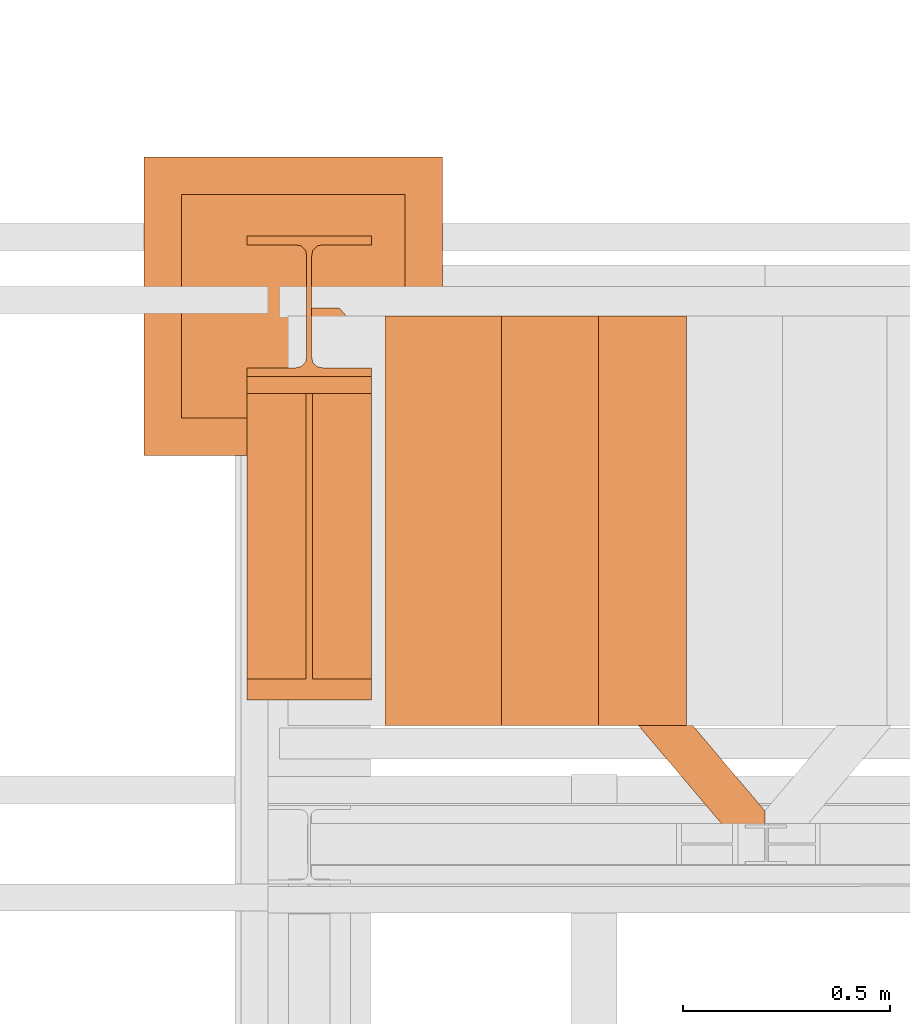
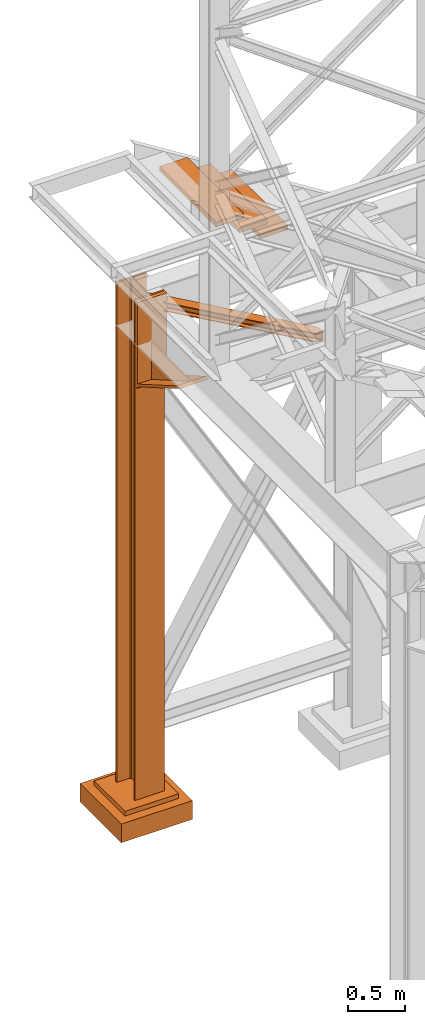
# One storey, part 132 of 208: 7 proxies.
"""IFC2X3 building model written with IfcOpenShell, lengths in millimetres."""

from ifc_helpers import new_model, entity, si_unit, converted_unit, frame, origin, origin_with_axes, place, context, subcontext, project, spatial, faceted_brep, material, element, save


model = new_model("IFC2X3")

# Units and contexts
model_context = context("Model", 3, precision=1e-05, world=origin())
plan_context = context("Plan", 3, precision=1e-05, world=origin())
body_context = subcontext(model_context, "Body", "Model", "MODEL_VIEW")
ifc_project = project(units=[si_unit("LENGTHUNIT", "METRE", prefix="MILLI"), converted_unit("PLANEANGLEUNIT", "DEGREE", entity("IfcPlaneAngleMeasure", 0.0174532925199433), si_unit("PLANEANGLEUNIT", "RADIAN"), dimensions=[0, 0, 0, 0, 0, 0, 0]), si_unit("AREAUNIT", "SQUARE_METRE"), si_unit("VOLUMEUNIT", "CUBIC_METRE")], contexts=[model_context, plan_context])

# Building, storey
building_placement = place(None, origin())
building = spatial("IfcBuilding", under=ifc_project, at=building_placement, CompositionType="COMPLEX")
storey_placement = place(building_placement, origin_with_axes())
storey = spatial("IfcBuildingStorey", under=building, at=storey_placement, Name="Geschoss", CompositionType="ELEMENT")

# Proxies
ifc_material = material(Name="35/80cm")
proxy_1_placement = place(storey_placement, frame((-3456.745037431798, -12632.57439531565, -65.01000000000022), z_axis=(0.0, 0.0, 1.0), x_axis=(1.0, 0.0, 0.0)))
element("IfcBuildingElementProxy", 1, at=proxy_1_placement, inside=storey, material=ifc_material, context=body_context, shape_type="Brep", body=[
    faceted_brep([(300.0100119209292, 0.01000000000021828, 0.01000000000027512), (300.0100119209292, 21.51000631809256, 0.01000000000027512), (183.0100057816508, 21.51000631809256, 0.01000000000027512), (169.036290997863, 24.30682016372703, 0.01000000000027512), (158.8068282401564, 34.53628850936912, 0.01000000000027512), (156.0100060126188, 48.51000143051169, 0.01000000000027512), (156.0100060126188, 291.5099946951868, 0.01000000000027512), (158.8068282401564, 305.48371506691, 0.01000000000027512), (169.036290997863, 315.7131685113909, 0.01000000000027512), (183.0100057816508, 318.5099972581866, 0.01000000000027512), (300.0100119209292, 318.5099972581866, 0.01000000000027512), (300.0100119209292, 340.0100035762789, 0.01000000000027512), (0.01000000000021828, 340.0100035762789, 0.01000000000027512), (0.01000000000021828, 318.5099972581866, 0.01000000000027512), (117.0100061392786, 318.5099972581866, 0.01000000000027512), (130.9837209230664, 315.7131685113909, 0.01000000000027512), (141.213183680773, 305.48371506691, 0.01000000000027512), (144.0100059083106, 291.5099946951868, 0.01000000000027512), (144.0100059083106, 48.51000143051169, 0.01000000000027512), (141.213183680773, 34.53628850936912, 0.01000000000027512), (130.9837209230664, 24.30682016372703, 0.01000000000027512), (117.0100061392786, 21.51000631809256, 0.01000000000027512), (0.01000000000021828, 21.51000631809256, 0.01000000000027512), (0.01000000000021828, 0.01000000000021828, 0.01000000000027512), (300.0100119209292, 21.51000631809256, 5350.010005364416), (300.0100119209292, 0.01000000000021828, 5350.010005364416), (0.01000000000021828, 0.01000000000021828, 5350.010005364416), (0.01000000000021828, 21.51000631809256, 5350.010005364416), (117.0100061392786, 21.51000631809256, 5350.010005364416), (130.9837209230664, 24.30682016372703, 5350.010005364416), (141.213183680773, 34.53628850936912, 5350.010005364416), (144.0100059083106, 48.51000143051169, 5350.010005364416), (144.0100059083106, 291.5099946951868, 5350.010005364416), (141.213183680773, 305.48371506691, 5350.010005364416), (130.9837209230664, 315.7131685113909, 5350.010005364416), (117.0100061392786, 318.5099972581866, 5350.010005364416), (0.01000000000021828, 318.5099972581866, 5350.010005364416), (0.01000000000021828, 340.0100035762789, 5350.010005364416), (300.0100119209292, 340.0100035762789, 5350.010005364416), (300.0100119209292, 318.5099972581866, 5350.010005364416), (183.0100057816508, 318.5099972581866, 5350.010005364416), (169.036290997863, 315.7131685113909, 5350.010005364416), (158.8068282401564, 305.48371506691, 5350.010005364416), (156.0100060126188, 291.5099946951868, 5350.010005364416), (156.0100060126188, 48.51000143051169, 5350.010005364416), (158.8068282401564, 34.53628850936912, 5350.010005364416), (169.036290997863, 24.30682016372703, 5350.010005364416), (183.0100057816508, 21.51000631809256, 5350.010005364416), (300.0100119209292, 21.51000631809256, 0.01000000000027512), (300.0100119209292, 0.01000000000021828, 0.01000000000027512), (300.0100119209292, 0.01000000000021828, 5350.010005364416), (300.0100119209292, 21.51000631809256, 5350.010005364416), (183.0100057816508, 21.51000631809256, 0.01000000000027512), (300.0100119209292, 21.51000631809256, 0.01000000000027512), (300.0100119209292, 21.51000631809256, 5350.010005364416), (183.0100057816508, 21.51000631809256, 5350.010005364416), (169.036290997863, 24.30682016372703, 0.01000000000027512), (183.0100057816508, 21.51000631809256, 0.01000000000027512), (183.0100057816508, 21.51000631809256, 5350.010005364416), (169.036290997863, 24.30682016372703, 5350.010005364416), (158.8068282401564, 34.53628850936912, 0.01000000000027512), (169.036290997863, 24.30682016372703, 0.01000000000027512), (169.036290997863, 24.30682016372703, 5350.010005364416), (158.8068282401564, 34.53628850936912, 5350.010005364416), (156.0100060126188, 48.51000143051169, 0.01000000000027512), (158.8068282401564, 34.53628850936912, 0.01000000000027512), (158.8068282401564, 34.53628850936912, 5350.010005364416), (156.0100060126188, 48.51000143051169, 5350.010005364416), (156.0100060126188, 291.5099946951868, 0.01000000000027512), (156.0100060126188, 48.51000143051169, 0.01000000000027512), (156.0100060126188, 48.51000143051169, 5350.010005364416), (156.0100060126188, 291.5099946951868, 5350.010005364416), (158.8068282401564, 305.48371506691, 0.01000000000027512), (156.0100060126188, 291.5099946951868, 0.01000000000027512), (156.0100060126188, 291.5099946951868, 5350.010005364416), (158.8068282401564, 305.48371506691, 5350.010005364416), (169.036290997863, 315.7131685113909, 0.01000000000027512), (158.8068282401564, 305.48371506691, 0.01000000000027512), (158.8068282401564, 305.48371506691, 5350.010005364416), (169.036290997863, 315.7131685113909, 5350.010005364416), (183.0100057816508, 318.5099972581866, 0.01000000000027512), (169.036290997863, 315.7131685113909, 0.01000000000027512), (169.036290997863, 315.7131685113909, 5350.010005364416), (183.0100057816508, 318.5099972581866, 5350.010005364416), (300.0100119209292, 318.5099972581866, 0.01000000000027512), (183.0100057816508, 318.5099972581866, 0.01000000000027512), (183.0100057816508, 318.5099972581866, 5350.010005364416), (300.0100119209292, 318.5099972581866, 5350.010005364416), (300.0100119209292, 340.0100035762789, 0.01000000000027512), (300.0100119209292, 318.5099972581866, 0.01000000000027512), (300.0100119209292, 318.5099972581866, 5350.010005364416), (300.0100119209292, 340.0100035762789, 5350.010005364416), (0.01000000000021828, 340.0100035762789, 0.01000000000027512), (300.0100119209292, 340.0100035762789, 0.01000000000027512), (300.0100119209292, 340.0100035762789, 5350.010005364416), (0.01000000000021828, 340.0100035762789, 5350.010005364416), (0.01000000000021828, 318.5099972581866, 0.01000000000027512), (0.01000000000021828, 340.0100035762789, 0.01000000000027512), (0.01000000000021828, 340.0100035762789, 5350.010005364416), (0.01000000000021828, 318.5099972581866, 5350.010005364416), (117.0100061392786, 318.5099972581866, 0.01000000000027512), (0.01000000000021828, 318.5099972581866, 0.01000000000027512), (0.01000000000021828, 318.5099972581866, 5350.010005364416), (117.0100061392786, 318.5099972581866, 5350.010005364416), (130.9837209230664, 315.7131685113909, 0.01000000000027512), (117.0100061392786, 318.5099972581866, 0.01000000000027512), (117.0100061392786, 318.5099972581866, 5350.010005364416), (130.9837209230664, 315.7131685113909, 5350.010005364416), (141.213183680773, 305.48371506691, 0.01000000000027512), (130.9837209230664, 315.7131685113909, 0.01000000000027512), (130.9837209230664, 315.7131685113909, 5350.010005364416), (141.213183680773, 305.48371506691, 5350.010005364416), (144.0100059083106, 291.5099946951868, 0.01000000000027512), (141.213183680773, 305.48371506691, 0.01000000000027512), (141.213183680773, 305.48371506691, 5350.010005364416), (144.0100059083106, 291.5099946951868, 5350.010005364416), (144.0100059083106, 48.51000143051169, 0.01000000000027512), (144.0100059083106, 291.5099946951868, 0.01000000000027512), (144.0100059083106, 291.5099946951868, 5350.010005364416), (144.0100059083106, 48.51000143051169, 5350.010005364416), (141.213183680773, 34.53628850936912, 0.01000000000027512), (144.0100059083106, 48.51000143051169, 0.01000000000027512), (144.0100059083106, 48.51000143051169, 5350.010005364416), (141.213183680773, 34.53628850936912, 5350.010005364416), (130.9837209230664, 24.30682016372703, 0.01000000000027512), (141.213183680773, 34.53628850936912, 0.01000000000027512), (141.213183680773, 34.53628850936912, 5350.010005364416), (130.9837209230664, 24.30682016372703, 5350.010005364416), (117.0100061392786, 21.51000631809256, 0.01000000000027512), (130.9837209230664, 24.30682016372703, 0.01000000000027512), (130.9837209230664, 24.30682016372703, 5350.010005364416), (117.0100061392786, 21.51000631809256, 5350.010005364416), (0.01000000000021828, 21.51000631809256, 0.01000000000027512), (117.0100061392786, 21.51000631809256, 0.01000000000027512), (117.0100061392786, 21.51000631809256, 5350.010005364416), (0.01000000000021828, 21.51000631809256, 5350.010005364416), (0.01000000000021828, 0.01000000000021828, 0.01000000000027512), (0.01000000000021828, 21.51000631809256, 0.01000000000027512), (0.01000000000021828, 21.51000631809256, 5350.010005364416), (0.01000000000021828, 0.01000000000021828, 5350.010005364416), (300.0100119209292, 0.01000000000021828, 0.01000000000027512), (0.01000000000021828, 0.01000000000021828, 0.01000000000027512), (0.01000000000021828, 0.01000000000021828, 5350.010005364416), (300.0100119209292, 0.01000000000021828, 5350.010005364416)], [[[0, 1, 2, 3, 4, 5, 6, 7, 8, 9, 10, 11, 12, 13, 14, 15, 16, 17, 18, 19, 20, 21, 22, 23]], [[24, 25, 26, 27, 28, 29, 30, 31, 32, 33, 34, 35, 36, 37, 38, 39, 40, 41, 42, 43, 44, 45, 46, 47]], [[48, 49, 50, 51]], [[52, 53, 54, 55]], [[56, 57, 58, 59]], [[60, 61, 62, 63]], [[64, 65, 66, 67]], [[68, 69, 70, 71]], [[72, 73, 74, 75]], [[76, 77, 78, 79]], [[80, 81, 82, 83]], [[84, 85, 86, 87]], [[88, 89, 90, 91]], [[92, 93, 94, 95]], [[96, 97, 98, 99]], [[100, 101, 102, 103]], [[104, 105, 106, 107]], [[108, 109, 110, 111]], [[112, 113, 114, 115]], [[116, 117, 118, 119]], [[120, 121, 122, 123]], [[124, 125, 126, 127]], [[128, 129, 130, 131]], [[132, 133, 134, 135]], [[136, 137, 138, 139]], [[140, 141, 142, 143]]], orient=[[False], [False], [False], [False], [False], [False], [False], [False], [False], [False], [False], [False], [False], [False], [False], [False], [False], [False], [False], [False], [False], [False], [False], [False], [False], [False]]),
])
proxy_2_placement = place(storey_placement, frame((-3456.745037431798, -13412.43639531566, 4367.230005364415), z_axis=(0.0, 0.0, 1.0), x_axis=(1.0, 0.0, 0.0)))
element("IfcBuildingElementProxy", 2, at=proxy_2_placement, inside=storey, context=body_context, shape_type="Brep", body=[
    faceted_brep([(0.01000000000021828, 739.8720000000012, 18.61000000000058), (0.01000000000021828, 0.01000000000021828, 445.7700000000004), (300.0100000000002, 0.01000000000021828, 445.7700000000004), (300.0100000000002, 739.8720000000012, 18.61000000000058), (0.01000000000021828, 0.01000000000021828, 445.7700000000004), (0.01000000000021828, 50.06600000000071, 445.7710000000006), (142.5100000000002, 50.06600000000071, 445.7710000000006), (142.5100000000002, 739.8720000000012, 445.7700000000004), (157.5100000000002, 739.8720000000012, 445.7700000000004), (157.5100000000002, 50.06600000000071, 445.7710000000006), (300.0100000000002, 50.06600000000071, 445.7710000000006), (300.0100000000002, 0.01000000000021828, 445.7700000000004), (0.01000000000021828, 50.06600000000071, 445.7710000000006), (0.01000000000021828, 739.8720000000012, 47.51000000000022), (142.5100000000002, 739.8720000000012, 47.51000000000022), (142.5100000000002, 50.06600000000071, 445.7710000000006), (157.5100000000002, 739.8720000000012, 47.51000000000022), (300.0100000000002, 739.8720000000012, 47.51000000000022), (300.0100000000002, 50.06600000000071, 445.7710000000006), (157.5100000000002, 50.06600000000071, 445.7710000000006), (0.01000000000021828, 739.8720000000012, 18.61000000000058), (0.01000000000021828, 739.8720000000012, 0.01000000000021828), (0.01000000000021828, 779.8720000000012, 0.01000000000021828), (0.01000000000021828, 779.8720000000012, 917.7700000000013), (0.01000000000021828, 739.8720000000012, 917.7700000000013), (0.01000000000021828, 739.8720000000012, 47.51000000000022), (0.01000000000021828, 50.06600000000071, 445.7710000000006), (0.01000000000021828, 0.01000000000021828, 445.7700000000004), (300.0100000000002, 779.8720000000012, 917.7700000000013), (300.0100000000002, 779.8720000000012, 0.01000000000021828), (300.0100000000002, 739.8720000000012, 0.01000000000021828), (300.0100000000002, 739.8720000000012, 18.61000000000058), (300.0100000000002, 0.01000000000021828, 445.7700000000004), (300.0100000000002, 50.06600000000071, 445.7710000000006), (300.0100000000002, 739.8720000000012, 47.51000000000022), (300.0100000000002, 739.8720000000012, 917.7700000000013), (300.0100000000002, 779.8720000000012, 917.7700000000013), (300.0100000000002, 739.8720000000012, 917.7700000000013), (0.01000000000021828, 739.8720000000012, 917.7700000000013), (0.01000000000021828, 779.8720000000012, 917.7700000000013), (300.0100000000002, 739.8720000000012, 917.7700000000013), (300.0100000000002, 739.8720000000012, 47.51000000000022), (157.5100000000002, 739.8720000000012, 47.51000000000022), (157.5100000000002, 739.8720000000012, 445.7700000000004), (142.5100000000002, 739.8720000000012, 445.7700000000004), (142.5100000000002, 739.8720000000012, 47.51000000000022), (0.01000000000021828, 739.8720000000012, 47.51000000000022), (0.01000000000021828, 739.8720000000012, 917.7700000000013), (300.0100000000002, 739.8720000000012, 18.61000000000058), (300.0100000000002, 739.8720000000012, 0.01000000000021828), (0.01000000000021828, 739.8720000000012, 0.01000000000021828), (0.01000000000021828, 739.8720000000012, 18.61000000000058), (300.0100000000002, 739.8720000000012, 0.01000000000021828), (300.0100000000002, 779.8720000000012, 0.01000000000021828), (0.01000000000021828, 779.8720000000012, 0.01000000000021828), (0.01000000000021828, 739.8720000000012, 0.01000000000021828), (300.0100000000002, 779.8720000000012, 0.01000000000021828), (300.0100000000002, 779.8720000000012, 917.7700000000013), (0.01000000000021828, 779.8720000000012, 917.7700000000013), (0.01000000000021828, 779.8720000000012, 0.01000000000021828), (142.5100000000002, 739.8720000000012, 47.51000000000022), (142.5100000000002, 739.8720000000012, 445.7700000000004), (142.5100000000002, 50.06600000000071, 445.7710000000006), (157.5100000000002, 739.8720000000012, 47.51000000000022), (157.5100000000002, 50.06600000000071, 445.7710000000006), (157.5100000000002, 739.8720000000012, 445.7700000000004)], [[[0, 1, 2, 3]], [[4, 5, 6, 7, 8, 9, 10, 11]], [[12, 13, 14, 15]], [[16, 17, 18, 19]], [[20, 21, 22, 23, 24, 25, 26, 27]], [[28, 29, 30, 31, 32, 33, 34, 35]], [[36, 37, 38, 39]], [[40, 41, 42, 43, 44, 45, 46, 47]], [[48, 49, 50, 51]], [[52, 53, 54, 55]], [[56, 57, 58, 59]], [[60, 61, 62]], [[63, 64, 65]]], orient=[[False], [False], [False], [False], [False], [False], [False], [False], [False], [False], [False], [False], [False]]),
])
proxy_3_placement = place(storey_placement, frame((-3300.745031419179, -13757.87439038569, 5101.990016164881), z_axis=(0.0, 0.0, 1.0), x_axis=(1.0, 0.0, 0.0)))
element("IfcBuildingElementProxy", 3, at=proxy_3_placement, inside=storey, context=body_context, shape_type="Brep", body=[
    faceted_brep([(1028.512359102908, 0.01000000000021828, 8.010001311302403), (1028.512359102908, 0.01000000000021828, 0.01000000000021828), (0.01000000000021828, 1215.51278803071, 0.01000000000021828), (0.01000000000021828, 1215.51278803071, 8.010001311303313), (1028.512359102908, 0.01000000000021828, 0.01000000000021828), (1094.009999947844, 0.01000000000021828, 0.01000000000021828), (1094.009999947844, 77.41630281674588, 0.01000000000021828), (67.46148411605282, 1290.610003345229, 0.01000000000021828), (0.01000000000021828, 1290.610003345229, 0.01000000000021828), (0.01000000000021828, 1215.51278803071, 0.01000000000021828), (1094.009999947844, 77.41630281674588, 0.01000000000021828), (1094.009999947846, 77.41630281674588, 8.010001311302403), (67.46148411605282, 1290.610003345229, 8.010001311302403), (67.46148411605282, 1290.610003345229, 0.01000000000021828), (1094.009999947846, 77.41630281674588, 8.010001311302403), (1094.009999947844, 22.45782827823496, 8.010001311302403), (20.95815950654287, 1290.610003345229, 8.010001311302403), (67.46148411605282, 1290.610003345229, 8.010001311302403), (1094.009999947844, 22.45782827823496, 8.010001311302403), (1094.009999947844, 12.84312897135897, 9.253033826351384), (12.82264470841801, 1290.610003345229, 9.253033826351384), (20.95815950654287, 1290.610003345229, 8.010001311302403), (1094.009999947844, 12.84312897135897, 9.253033826351384), (1094.009999947844, 5.804685632951077, 13.79946006298087), (6.86703880668756, 1290.610003345229, 13.79946006298087), (12.82264470841801, 1290.610003345229, 9.253033826351384), (1094.009999947844, 5.804685632951077, 13.79946006298087), (1094.009999947844, 3.880315357109794, 20.01000141561053), (5.23872549636144, 1290.610003345229, 20.01000141560962), (6.86703880668756, 1290.610003345229, 13.79946006298087), (1094.009999947844, 3.880315357109794, 20.01000141561053), (1094.009999947844, 3.880315357111613, 76.01000128150008), (5.23872549636144, 1290.610003345229, 76.01000128150008), (5.23872549636144, 1290.610003345229, 20.01000141560962), (1094.009999947844, 3.880315357111613, 76.01000128150008), (1094.009999947844, 5.804685632951077, 82.2205407714846), (6.86703880668756, 1290.610003345229, 82.2205407714846), (5.23872549636144, 1290.610003345229, 76.01000128150008), (1094.009999947844, 5.804685632951077, 82.2205407714846), (1094.009999947844, 12.84312897135897, 86.76696700811408), (12.82264470841801, 1290.610003345229, 86.76696700811317), (6.86703880668756, 1290.610003345229, 82.2205407714846), (1094.009999947844, 12.84312897135897, 86.76696700811408), (1094.009999947844, 22.45782827823496, 88.00999952316306), (20.95815950654469, 1290.610003345229, 88.00999952316306), (12.82264470841801, 1290.610003345229, 86.76696700811317), (1094.009999947844, 22.45782827823496, 88.00999952316306), (1094.009999947844, 77.41630281674588, 88.00999952316306), (67.46148411605282, 1290.610003345229, 88.00999952316397), (20.95815950654469, 1290.610003345229, 88.00999952316306), (1094.009999947844, 77.41630281674588, 88.00999952316306), (1094.009999947846, 77.41630281674406, 96.01000083446525), (67.46148411605282, 1290.610003345229, 96.01000083446525), (67.46148411605282, 1290.610003345229, 88.00999952316397), (1094.009999947846, 77.41630281674406, 96.01000083446525), (1094.009999947846, 0.01000000000021828, 96.01000083446525), (1028.51235910291, 0.01000000000021828, 96.01000083446525), (0.01000000000021828, 1215.512788030712, 96.01000083446525), (0.01000000000021828, 1290.610003345229, 96.01000083446525), (67.46148411605282, 1290.610003345229, 96.01000083446525), (1028.51235910291, 0.01000000000021828, 96.01000083446525), (1028.51235910291, 0.01000000000021828, 88.00999952316306), (0.01000000000021828, 1215.51278803071, 88.00999952316306), (0.01000000000021828, 1215.512788030712, 96.01000083446525), (1028.51235910291, 0.01000000000021828, 88.00999952316306), (1075.01568371242, 0.01000000000021828, 88.00999952316306), (0.01000000000021828, 1270.471262569225, 88.00999952316215), (0.01000000000021828, 1215.51278803071, 88.00999952316306), (1075.01568371242, 0.01000000000021828, 88.00999952316306), (1083.151198510544, 0.01000000000021828, 86.76696700811408), (0.01000000000021828, 1280.085961876101, 86.76696700811499), (0.01000000000021828, 1270.471262569225, 88.00999952316215), (1083.151198510544, 0.01000000000021828, 86.76696700811408), (1089.106804412275, 0.01000000000021828, 82.2205407714846), (0.01000000000021828, 1287.124405214507, 82.2205407714855), (0.01000000000021828, 1280.085961876101, 86.76696700811499), (1089.106804412275, 0.01000000000021828, 82.2205407714846), (1090.735117722603, 0.01000000000021828, 76.01000128150008), (0.01000000000021828, 1289.04877549035, 76.01000128150008), (0.01000000000021828, 1287.124405214507, 82.2205407714855), (1090.735117722603, 0.01000000000021828, 76.01000128150008), (1090.735117722601, 0.01000000000021828, 20.01000141561053), (0.01000000000021828, 1289.04877549035, 20.01000141561053), (0.01000000000021828, 1289.04877549035, 76.01000128150008), (1090.735117722601, 0.01000000000021828, 20.01000141561053), (1089.106804412275, 0.01000000000021828, 13.79946006298087), (0.01000000000021828, 1287.124405214508, 13.79946006298087), (0.01000000000021828, 1289.04877549035, 20.01000141561053), (1089.106804412275, 0.01000000000021828, 13.79946006298087), (1083.151198510544, 0.01000000000021828, 9.253033826351384), (0.01000000000021828, 1280.085961876101, 9.253033826351384), (0.01000000000021828, 1287.124405214508, 13.79946006298087), (1083.151198510544, 0.01000000000021828, 9.253033826351384), (1075.015683712418, 0.01000000000021828, 8.010001311302403), (0.01000000000021828, 1270.471262569225, 8.010001311302403), (0.01000000000021828, 1280.085961876101, 9.253033826351384), (1075.015683712418, 0.01000000000021828, 8.010001311302403), (1028.512359102908, 0.01000000000021828, 8.010001311302403), (0.01000000000021828, 1215.51278803071, 8.010001311303313), (0.01000000000021828, 1270.471262569225, 8.010001311302403), (1094.009999947844, 77.41630281674588, 0.01000000000021828), (1094.009999947844, 0.01000000000021828, 0.01000000000021828), (1094.009999947846, 0.01000000000021828, 96.01000083446525), (1094.009999947846, 77.41630281674406, 96.01000083446525), (1094.009999947844, 77.41630281674588, 88.00999952316306), (1094.009999947844, 22.45782827823496, 88.00999952316306), (1094.009999947844, 12.84312897135897, 86.76696700811408), (1094.009999947844, 5.804685632951077, 82.2205407714846), (1094.009999947844, 3.880315357111613, 76.01000128150008), (1094.009999947844, 3.880315357109794, 20.01000141561053), (1094.009999947844, 5.804685632951077, 13.79946006298087), (1094.009999947844, 12.84312897135897, 9.253033826351384), (1094.009999947844, 22.45782827823496, 8.010001311302403), (1094.009999947846, 77.41630281674588, 8.010001311302403), (1094.009999947846, 0.01000000000021828, 96.01000083446525), (1094.009999947844, 0.01000000000021828, 0.01000000000021828), (1028.512359102908, 0.01000000000021828, 0.01000000000021828), (1028.512359102908, 0.01000000000021828, 8.010001311302403), (1075.015683712418, 0.01000000000021828, 8.010001311302403), (1083.151198510544, 0.01000000000021828, 9.253033826351384), (1089.106804412275, 0.01000000000021828, 13.79946006298087), (1090.735117722601, 0.01000000000021828, 20.01000141561053), (1090.735117722603, 0.01000000000021828, 76.01000128150008), (1089.106804412275, 0.01000000000021828, 82.2205407714846), (1083.151198510544, 0.01000000000021828, 86.76696700811408), (1075.01568371242, 0.01000000000021828, 88.00999952316306), (1028.51235910291, 0.01000000000021828, 88.00999952316306), (1028.51235910291, 0.01000000000021828, 96.01000083446525), (0.01000000000021828, 1215.51278803071, 0.01000000000021828), (0.01000000000021828, 1290.610003345229, 0.01000000000021828), (0.01000000000021828, 1290.610003345229, 96.01000083446525), (0.01000000000021828, 1215.512788030712, 96.01000083446525), (0.01000000000021828, 1215.51278803071, 88.00999952316306), (0.01000000000021828, 1270.471262569225, 88.00999952316215), (0.01000000000021828, 1280.085961876101, 86.76696700811499), (0.01000000000021828, 1287.124405214507, 82.2205407714855), (0.01000000000021828, 1289.04877549035, 76.01000128150008), (0.01000000000021828, 1289.04877549035, 20.01000141561053), (0.01000000000021828, 1287.124405214508, 13.79946006298087), (0.01000000000021828, 1280.085961876101, 9.253033826351384), (0.01000000000021828, 1270.471262569225, 8.010001311302403), (0.01000000000021828, 1215.51278803071, 8.010001311303313), (67.46148411605282, 1290.610003345229, 0.01000000000021828), (67.46148411605282, 1290.610003345229, 8.010001311302403), (20.95815950654287, 1290.610003345229, 8.010001311302403), (12.82264470841801, 1290.610003345229, 9.253033826351384), (6.86703880668756, 1290.610003345229, 13.79946006298087), (5.23872549636144, 1290.610003345229, 20.01000141560962), (5.23872549636144, 1290.610003345229, 76.01000128150008), (6.86703880668756, 1290.610003345229, 82.2205407714846), (12.82264470841801, 1290.610003345229, 86.76696700811317), (20.95815950654469, 1290.610003345229, 88.00999952316306), (67.46148411605282, 1290.610003345229, 88.00999952316397), (67.46148411605282, 1290.610003345229, 96.01000083446525), (0.01000000000021828, 1290.610003345229, 96.01000083446525), (0.01000000000021828, 1290.610003345229, 0.01000000000021828)], [[[0, 1, 2, 3]], [[4, 5, 6, 7, 8, 9]], [[10, 11, 12, 13]], [[14, 15, 16, 17]], [[18, 19, 20, 21]], [[22, 23, 24, 25]], [[26, 27, 28, 29]], [[30, 31, 32, 33]], [[34, 35, 36, 37]], [[38, 39, 40, 41]], [[42, 43, 44, 45]], [[46, 47, 48, 49]], [[50, 51, 52, 53]], [[54, 55, 56, 57, 58, 59]], [[60, 61, 62, 63]], [[64, 65, 66, 67]], [[68, 69, 70, 71]], [[72, 73, 74, 75]], [[76, 77, 78, 79]], [[80, 81, 82, 83]], [[84, 85, 86, 87]], [[88, 89, 90, 91]], [[92, 93, 94, 95]], [[96, 97, 98, 99]], [[100, 101, 102, 103, 104, 105, 106, 107, 108, 109, 110, 111, 112, 113]], [[114, 115, 116, 117, 118, 119, 120, 121, 122, 123, 124, 125, 126, 127]], [[128, 129, 130, 131, 132, 133, 134, 135, 136, 137, 138, 139, 140, 141]], [[142, 143, 144, 145, 146, 147, 148, 149, 150, 151, 152, 153, 154, 155]]], orient=[[False], [False], [False], [False], [False], [False], [False], [False], [False], [False], [False], [False], [False], [False], [False], [False], [False], [False], [False], [False], [False], [False], [False], [False], [False], [False], [False], [False]]),
])
proxy_4_placement = place(storey_placement, frame((-3705.215590090974, -12822.57439725281, -315.01), z_axis=(0.0, 0.0, 1.0), x_axis=(1.0, 0.0, 0.0)))
element("IfcBuildingElementProxy", 4, at=proxy_4_placement, inside=storey, context=body_context, shape_type="Brep", body=[
    faceted_brep([(630.0100000000002, 630.0100000000002, 250.01), (630.0100000000002, 90.01000000000022, 250.01), (90.01000000000022, 90.01000000000022, 250.01), (90.01000000000022, 630.0100000000002, 250.01), (630.0100000000002, 630.0100000000002, 200.01), (630.0100000000002, 90.01000000000022, 200.01), (630.0100000000002, 90.01000000000022, 250.01), (630.0100000000002, 630.0100000000002, 250.01), (90.01000000000022, 630.0100000000002, 200.01), (630.0100000000002, 630.0100000000002, 200.01), (630.0100000000002, 630.0100000000002, 250.01), (90.01000000000022, 630.0100000000002, 250.01), (90.01000000000022, 90.01000000000022, 200.01), (90.01000000000022, 630.0100000000002, 200.01), (90.01000000000022, 630.0100000000002, 250.01), (90.01000000000022, 90.01000000000022, 250.01), (630.0100000000002, 90.01000000000022, 200.01), (90.01000000000022, 90.01000000000022, 200.01), (90.01000000000022, 90.01000000000022, 250.01), (630.0100000000002, 90.01000000000022, 250.01), (720.0100000000002, 0.01000000000021828, 0.009999999999990905), (720.0100000000002, 720.0100000000002, 0.009999999999990905), (0.01000000000021828, 720.0100000000002, 0.009999999999990905), (0.01000000000021828, 0.01000000000021828, 0.009999999999990905), (720.0100000000002, 720.0100000000002, 200.01), (720.0100000000002, 0.01000000000021828, 200.01), (0.01000000000021828, 0.01000000000021828, 200.01), (0.01000000000021828, 720.0100000000002, 200.01), (90.01000000000022, 90.01000000000022, 200.01), (630.0100000000002, 90.01000000000022, 200.01), (630.0100000000002, 630.0100000000002, 200.01), (90.01000000000022, 630.0100000000002, 200.01), (720.0100000000002, 720.0100000000002, 0.009999999999990905), (720.0100000000002, 0.01000000000021828, 0.009999999999990905), (720.0100000000002, 0.01000000000021828, 200.01), (720.0100000000002, 720.0100000000002, 200.01), (0.01000000000021828, 720.0100000000002, 0.009999999999990905), (720.0100000000002, 720.0100000000002, 0.009999999999990905), (720.0100000000002, 720.0100000000002, 200.01), (0.01000000000021828, 720.0100000000002, 200.01), (0.01000000000021828, 0.01000000000021828, 0.009999999999990905), (0.01000000000021828, 720.0100000000002, 0.009999999999990905), (0.01000000000021828, 720.0100000000002, 200.01), (0.01000000000021828, 0.01000000000021828, 200.01), (720.0100000000002, 0.01000000000021828, 0.009999999999990905), (0.01000000000021828, 0.01000000000021828, 0.009999999999990905), (0.01000000000021828, 0.01000000000021828, 200.01), (720.0100000000002, 0.01000000000021828, 200.01)], [[[0, 1, 2, 3]], [[4, 5, 6, 7]], [[8, 9, 10, 11]], [[12, 13, 14, 15]], [[16, 17, 18, 19]], [[20, 21, 22, 23]], [[24, 25, 26, 27], [28, 29, 30, 31]], [[32, 33, 34, 35]], [[36, 37, 38, 39]], [[40, 41, 42, 43]], [[44, 45, 46, 47]]], orient=[[False], [False], [False], [False], [False], [False], [False, False], [False], [False], [False], [False]]),
])
for number, where, z_axis, x_axis in (
    (5, (-2676.526415575506, -13474.7262510599, 6179.621503199068), (0.0, 0.0, 1.0), (1.0, 0.0, 0.0)),
    (6, (-2889.02327878041, -13474.7262510599, 6316.648265018103), (0.0, 0.0, 1.0), (1.0, 0.0, 0.0)),
    (7, (-3123.287934412027, -13474.7262510599, 6463.70404147361), (0.0, 0.0, 1.0), (1.0, 0.0, 0.0)),
):
    element("IfcBuildingElementProxy", number, at=place(storey_placement, frame(where, z_axis=z_axis, x_axis=x_axis)), inside=storey, context=body_context, shape_type="Brep", body=[
        faceted_brep([(0.01000000000021828, 0.01000000000021828, 0.01000000000021828), (280.2746556316179, 0.01000000000021828, 0.01000000000021828), (280.2746556316179, 988.9080206708586, 0.01000000000021828), (0.01000000000021828, 988.9080206708586, 0.01000000000021828), (280.2746556316179, 0.01000000000021828, 50.01000000000022), (0.01000000000021828, 0.01000000000021828, 50.01000000000022), (0.01000000000021828, 988.9080206708586, 50.01000000000022), (280.2746556316179, 988.9080206708586, 50.01000000000022), (280.2746556316179, 0.01000000000021828, 0.01000000000021828), (0.01000000000021828, 0.01000000000021828, 0.01000000000021828), (0.01000000000021828, 0.01000000000021828, 50.01000000000022), (280.2746556316179, 0.01000000000021828, 50.01000000000022), (280.2746556316179, 988.9080206708586, 0.01000000000021828), (280.2746556316179, 0.01000000000021828, 0.01000000000021828), (280.2746556316179, 0.01000000000021828, 50.01000000000022), (280.2746556316179, 988.9080206708586, 50.01000000000022), (0.01000000000021828, 988.9080206708586, 0.01000000000021828), (280.2746556316179, 988.9080206708586, 0.01000000000021828), (280.2746556316179, 988.9080206708586, 50.01000000000022), (0.01000000000021828, 988.9080206708586, 50.01000000000022), (0.01000000000021828, 0.01000000000021828, 0.01000000000021828), (0.01000000000021828, 988.9080206708586, 0.01000000000021828), (0.01000000000021828, 988.9080206708586, 50.01000000000022), (0.01000000000021828, 0.01000000000021828, 50.01000000000022)], [[[0, 1, 2, 3]], [[4, 5, 6, 7]], [[8, 9, 10, 11]], [[12, 13, 14, 15]], [[16, 17, 18, 19]], [[20, 21, 22, 23]]], orient=[[False], [False], [False], [False], [False], [False]]),
    ])

save(model, "model.ifc")
